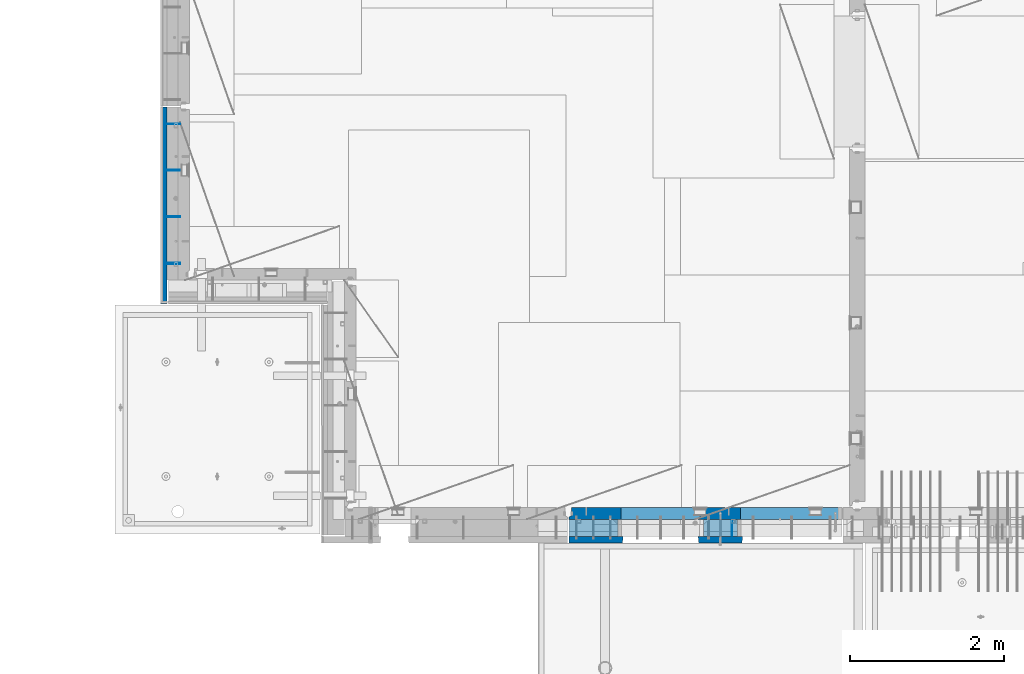
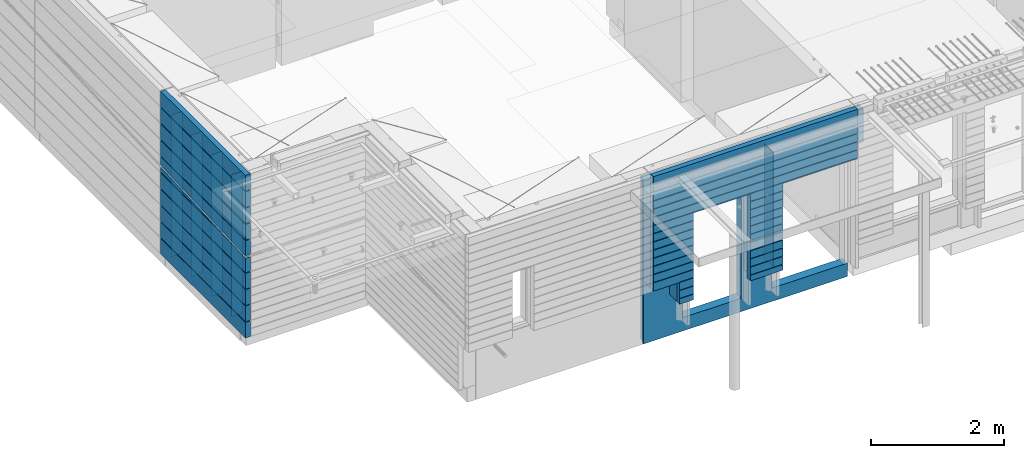
# One storey, part 207 of 325: 10 walls, 2 elements without a shape of their own.
"""IFC2X3 building model written with IfcOpenShell, lengths in millimetres."""

from ifc_helpers import new_model, si_unit, frame, origin_with_axes, place, context, subcontext, project, spatial, faceted_brep, material, type_object, element, aggregate, save


model = new_model("IFC2X3")

# Units and contexts
model_context = context("Model", 3, precision=1e-05, world=origin_with_axes())
body_context = subcontext(model_context, "Body", "Model", "MODEL_VIEW")
ifc_project = project(units=[si_unit("LENGTHUNIT", "METRE", prefix="MILLI"), si_unit("AREAUNIT", "SQUARE_METRE"), si_unit("VOLUMEUNIT", "CUBIC_METRE"), si_unit("MASSUNIT", "GRAM", prefix="KILO"), si_unit("TIMEUNIT", "SECOND"), si_unit("PLANEANGLEUNIT", "RADIAN"), si_unit("SOLIDANGLEUNIT", "STERADIAN"), si_unit("THERMODYNAMICTEMPERATUREUNIT", "DEGREE_CELSIUS"), si_unit("LUMINOUSINTENSITYUNIT", "LUMEN")], contexts=[model_context])

# Site, building, storey
site_placement = place(None, origin_with_axes())
site = spatial("IfcSite", under=ifc_project, at=site_placement, CompositionType="ELEMENT")
building_placement = place(site_placement, origin_with_axes())
building = spatial("IfcBuilding", under=site, at=building_placement, CompositionType="ELEMENT")
storey_placement = place(building_placement, origin_with_axes())
storey = spatial("IfcBuildingStorey", under=building, at=storey_placement, Name="1", CompositionType="ELEMENT", Elevation=0.0)

# Assembly, walls
assembly_1_placement = place(storey_placement, origin_with_axes())
assembly_1 = element("IfcElementAssembly", 1, at=assembly_1_placement, inside=storey, AssemblyPlace="NOTDEFINED", PredefinedType="REINFORCEMENT_UNIT")
ifc_material_1 = material(Name="Undefined")
wall_type_1 = type_object("IfcWallType", PredefinedType="NOTDEFINED")
wall_1_placement = place(assembly_1_placement, frame((7880.0, 11165.0, 83115.0), z_axis=(0.0, 0.0, 1.0), x_axis=(-1.0, 3.00000001838171e-08, 0.0)))
wall_1 = element("IfcWall", 2, at=wall_1_placement, type_object=wall_type_1, material=ifc_material_1, Name="(PD)", context=body_context, shape_type="Brep", body=[
    faceted_brep([(0.0, 5.0, -1300.0), (0.0, 5.0, 1300.0), (200.0, 5.0, 1300.0), (200.0, 5.0, -1300.0), (0.0, -5.0, 1300.0), (200.0, -5.0, 1300.0), (0.0, -5.0, -1300.0), (200.0, -5.0, -1300.0)], [[[0, 1, 2, 3]], [[1, 4, 5, 2]], [[4, 6, 7, 5]], [[6, 0, 3, 7]], [[5, 7, 3, 2]], [[6, 4, 1, 0]]]),
])
wall_2_placement = place(assembly_1_placement, frame((7880.0, 12975.0, 83115.0), z_axis=(0.0, 0.0, 1.0), x_axis=(-1.0, 3.00000001838171e-08, 0.0)))
wall_2 = element("IfcWall", 3, at=wall_2_placement, type_object=wall_type_1, material=ifc_material_1, Name="(PD)", context=body_context, shape_type="Brep", body=[
    faceted_brep([(0.0, 5.0, -1300.0), (0.0, 5.0, 1300.0), (200.0, 5.0, 1300.0), (200.0, 5.0, -1300.0), (0.0, -5.0, 1300.0), (200.0, -5.0, 1300.0), (0.0, -5.0, -1300.0), (200.0, -5.0, -1300.0)], [[[0, 1, 2, 3]], [[1, 4, 5, 2]], [[4, 6, 7, 5]], [[6, 0, 3, 7]], [[5, 7, 3, 2]], [[6, 4, 1, 0]]]),
])
wall_3_placement = place(assembly_1_placement, frame((7880.0, 12375.0, 83115.0), z_axis=(0.0, 0.0, 1.0), x_axis=(-1.0, 3.00000001838171e-08, 0.0)))
wall_3 = element("IfcWall", 4, at=wall_3_placement, type_object=wall_type_1, material=ifc_material_1, Name="(PD)", context=body_context, shape_type="Brep", body=[
    faceted_brep([(0.0, 5.0, -1300.0), (0.0, 5.0, 1300.0), (200.0, 5.0, 1300.0), (200.0, 5.0, -1300.0), (0.0, -5.0, 1300.0), (200.0, -5.0, 1300.0), (0.0, -5.0, -1300.0), (200.0, -5.0, -1300.0)], [[[0, 1, 2, 3]], [[1, 4, 5, 2]], [[4, 6, 7, 5]], [[6, 0, 3, 7]], [[5, 7, 3, 2]], [[6, 4, 1, 0]]]),
])
wall_4_placement = place(assembly_1_placement, frame((7880.0, 11775.0, 83115.0), z_axis=(0.0, 0.0, 1.0), x_axis=(-1.0, 3.00000001838171e-08, 0.0)))
wall_4 = element("IfcWall", 5, at=wall_4_placement, type_object=wall_type_1, material=ifc_material_1, Name="(PD)", context=body_context, shape_type="Brep", body=[
    faceted_brep([(0.0, 5.0, -1300.0), (0.0, 5.0, 1300.0), (200.0, 5.0, 1300.0), (200.0, 5.0, -1300.0), (0.0, -5.0, 1300.0), (200.0, -5.0, 1300.0), (0.0, -5.0, -1300.0), (200.0, -5.0, -1300.0)], [[[0, 1, 2, 3]], [[1, 4, 5, 2]], [[4, 6, 7, 5]], [[6, 0, 3, 7]], [[5, 7, 3, 2]], [[6, 4, 1, 0]]]),
])
wall_5_placement = place(assembly_1_placement, frame((7880.0, 11175.0, 83115.0), z_axis=(0.0, 0.0, 1.0), x_axis=(-1.0, 3.00000001838171e-08, 0.0)))
wall_5 = element("IfcWall", 6, at=wall_5_placement, type_object=wall_type_1, material=ifc_material_1, Name="(PD)", context=body_context, shape_type="Brep", body=[
    faceted_brep([(0.0, 5.0, -1300.0), (0.0, 5.0, 1300.0), (200.0, 5.0, 1300.0), (200.0, 5.0, -1300.0), (0.0, -5.0, 1300.0), (200.0, -5.0, 1300.0), (0.0, -5.0, -1300.0), (200.0, -5.0, -1300.0)], [[[0, 1, 2, 3]], [[1, 4, 5, 2]], [[4, 6, 7, 5]], [[6, 0, 3, 7]], [[5, 7, 3, 2]], [[6, 4, 1, 0]]]),
])
ifc_material_2 = material(Name="CONCRETE/C30/37")
wall_type_2 = type_object("IfcWallType", PredefinedType="NOTDEFINED")
wall_6_placement = place(assembly_1_placement, frame((7667.5, 10645.0, 83247.5), z_axis=(0.0, 0.0, 1.0), x_axis=(0.0, 1.0, 0.0)))
wall_6 = element("IfcWall", 7, at=wall_6_placement, type_object=wall_type_2, material=ifc_material_2, context=body_context, shape_type="Brep", body=[
    faceted_brep([(0.000115201512016938, 12.4999999999982, -32.6842012733541), (30.0001152015138, 12.4999999999964, -32.6842012732959), (30.0001152015138, 12.4999999999982, -31.2185204170964), (30.0001152015138, -42.4999999999991, -32.6842015973234), (0.0, -42.5, -32.6842015973234), (30.0001152015138, -42.4999999999991, 17.3157872826123), (30.0001152015138, 12.4999999999936, 17.3157872826123), (0.0, -42.5, 17.3157872826123), (4.43547978647985e-05, 12.4999999999982, 17.3157955949428), (0.0, 42.5, 1492.5), (2550.0, 42.5, 1492.5), (2550.0, 42.5, 1206.99999988925), (0.0, 42.5, 1206.99999988925), (2550.0, 32.4999991121613, 1205.00000040043), (10.0000008873085, 32.4999991121613, 1205.00000040043), (2550.0, 32.4999992501671, 1194.99999999921), (10.0000007493072, 32.4999992501671, 1194.99999999921), (2550.0, 42.5, 1192.99999994476), (0.0, 42.5, 1192.99999994476), (2550.0, 42.5, 906.999999889245), (0.0, 42.5, 906.999999889245), (2550.0, 32.4999991121613, 905.000000400425), (10.0000008873085, 32.4999991121613, 905.000000400425), (2550.0, 32.4999992501671, 894.999999999214), (10.0000007493072, 32.4999992501671, 894.999999999214), (2550.0, 42.5, 892.999999944761), (0.0, 42.5, 892.999999944761), (2550.0, 42.5, 606.999999889245), (0.0, 42.5, 606.999999889245), (2550.0, 32.4999991121613, 605.000000400425), (10.0000008873085, 32.4999991121613, 605.000000400425), (2550.0, 32.4999992501671, 594.999999999214), (10.0000007493072, 32.4999992501671, 594.999999999214), (2550.0, 42.5, 592.999999944761), (0.0, 42.5, 592.999999944761), (2550.0, 42.5, 306.999999889245), (0.0, 42.5, 306.999999889245), (2550.0, 32.4999991121613, 305.000000400425), (10.0000008873085, 32.4999991121613, 305.000000400425), (2550.0, 32.4999992501671, 294.999999999214), (10.0000007493072, 32.4999992501671, 294.999999999214), (2550.0, 42.5, 292.999999944761), (0.0, 42.5, 292.999999944761), (10.0000007493072, -42.5, 294.9999999992), (0.0, -42.5, 292.999999944761), (10.0000008873085, -42.5, 305.000000400425), (0.0, -42.5, 306.999999889245), (0.0, -42.5, 592.999999944761), (10.0000007493072, -42.5000000000009, 594.9999999992), (10.0000008873085, -42.5000000000009, 605.000000400425), (0.0, -42.5, 606.999999889245), (0.0, -42.5, 892.999999944761), (10.0000007493072, -42.5, 894.9999999992), (10.0000008873085, -42.5, 905.000000400425), (0.0, -42.5, 906.999999889245), (0.0, -42.5, 1192.99999994476), (10.0000007493072, -42.5, 1194.9999999992), (10.0000008873085, -42.5, 1205.00000040043), (0.0, -42.5, 1206.99999988925), (0.0, -42.5, 1492.5), (2550.0, -42.5, 1492.5), (2550.0, 42.5, 6.99999988924537), (812.268372506769, 42.5, 6.99999988924537), (2550.0, 42.5, 91.8986658797949), (2550.0, 32.4999991121613, 5.00000040042505), (771.331776788546, 32.4999991121613, 5.00000040042505), (2550.0, 32.4999992501671, -5.0000000007858), (566.648737670199, 32.4999992501671, -5.0000000007858), (2550.0, 42.5, -7.00000005523907), (525.712130374386, 42.5, -7.00000005523907), (2550.0, 42.5, -293.000000110755), (0.0, 42.5, -293.000000110755), (0.0, 42.5, -32.6842012733541), (2550.0, 32.4999991121613, -294.999999599575), (10.0000008873085, 32.4999991121613, -294.999999599575), (2550.0, 32.4999992501671, -305.000000000786), (10.0000007493072, 32.4999992501671, -305.000000000786), (2550.0, 42.5, -307.000000055239), (0.0, 42.5, -307.000000055239), (2550.0, 42.5, -593.000000110755), (0.0, 42.5, -593.000000110755), (2550.0, 32.4999991121613, -594.999999599575), (10.0000008873085, 32.4999991121613, -594.999999599575), (2550.0, 32.4999992501671, -605.000000000786), (10.0000007493072, 32.4999992501671, -605.000000000786), (2550.0, 42.5, -607.000000055239), (0.0, 42.5, -607.000000055239), (2550.0, 42.5, -893.000000110755), (0.0, 42.5, -893.000000110755), (2550.0, 32.4999991121613, -894.999999599575), (10.0000008873085, 32.4999991121613, -894.999999599575), (2550.0, 32.4999992501671, -905.000000000786), (10.0000007493072, 32.4999992501671, -905.000000000786), (2550.0, 42.5, -907.000000055239), (0.0, 42.5, -907.000000055239), (2550.0, 42.5, -1193.00000011075), (0.0, 42.5, -1193.00000011075), (2550.0, 32.4999991121613, -1194.99999959957), (10.0000008873085, 32.4999991121613, -1194.99999959957), (2550.0, 32.4999992501671, -1205.00000000079), (10.0000007493072, 32.4999992501671, -1205.00000000079), (2550.0, 42.5, -1207.00000005524), (0.0, 42.5, -1207.00000005524), (2550.0, 42.5, -1492.5), (0.0, 42.5, -1492.5), (0.0, -42.5, -1492.5), (2550.0, -42.5, -1492.5), (0.0, -42.5, -1207.00000005524), (10.0000007493072, -42.5, -1205.0000000008), (10.0000008873085, -42.5, -1194.99999959957), (0.0, -42.5, -1193.00000011075), (0.0, -42.5, -907.000000055239), (10.0000007493072, -42.5, -905.0000000008), (10.0000008873085, -42.5, -894.999999599575), (0.0, -42.5, -893.000000110755), (0.0, -42.5, -607.000000055239), (10.0000007493072, -42.5, -605.0000000008), (10.0000008873085, -42.5, -594.999999599575), (0.0, -42.5, -593.000000110755), (0.0, -42.5, -307.000000055239), (10.0000007493072, -42.5, -305.0000000008), (10.0000008873085, -42.5, -294.999999599575), (0.0, -42.5, -293.000000110755), (2549.99999999073, 12.4999999999982, 91.8986658797949), (2550.0, 12.4999999999982, 141.86737513663), (2550.0, 42.5, 141.898665707573), (0.0, 42.5, 17.3157955949428)], [[[0, 1, 2]], [[3, 1, 0, 4]], [[5, 6, 2, 1, 3]], [[7, 8, 6, 5]], [[9, 10, 11, 12]], [[11, 13, 14, 12]], [[13, 15, 16, 14]], [[15, 17, 18, 16]], [[19, 20, 18, 17]], [[19, 21, 22, 20]], [[21, 23, 24, 22]], [[23, 25, 26, 24]], [[27, 28, 26, 25]], [[27, 29, 30, 28]], [[29, 31, 32, 30]], [[31, 33, 34, 32]], [[35, 36, 34, 33]], [[35, 37, 38, 36]], [[37, 39, 40, 38]], [[39, 41, 42, 40]], [[43, 40, 42, 44]], [[45, 38, 40, 43]], [[46, 36, 38, 45]], [[36, 46, 47, 34]], [[48, 32, 34, 47]], [[49, 30, 32, 48]], [[50, 28, 30, 49]], [[28, 50, 51, 26]], [[52, 24, 26, 51]], [[53, 22, 24, 52]], [[54, 20, 22, 53]], [[20, 54, 55, 18]], [[56, 16, 18, 55]], [[57, 14, 16, 56]], [[58, 12, 14, 57]], [[59, 9, 12, 58]], [[9, 59, 60, 10]], [[61, 62, 63]], [[61, 64, 65, 62]], [[64, 66, 67, 65]], [[66, 68, 69, 67]], [[68, 70, 71, 72, 69]], [[70, 73, 74, 71]], [[73, 75, 76, 74]], [[75, 77, 78, 76]], [[79, 80, 78, 77]], [[79, 81, 82, 80]], [[81, 83, 84, 82]], [[83, 85, 86, 84]], [[87, 88, 86, 85]], [[87, 89, 90, 88]], [[89, 91, 92, 90]], [[91, 93, 94, 92]], [[95, 96, 94, 93]], [[95, 97, 98, 96]], [[97, 99, 100, 98]], [[99, 101, 102, 100]], [[103, 104, 102, 101]], [[105, 104, 103, 106]], [[104, 105, 107, 102]], [[108, 100, 102, 107]], [[109, 98, 100, 108]], [[110, 96, 98, 109]], [[96, 110, 111, 94]], [[112, 92, 94, 111]], [[113, 90, 92, 112]], [[114, 88, 90, 113]], [[88, 114, 115, 86]], [[116, 84, 86, 115]], [[117, 82, 84, 116]], [[118, 80, 82, 117]], [[80, 118, 119, 78]], [[120, 76, 78, 119]], [[121, 74, 76, 120]], [[122, 71, 74, 121]], [[72, 71, 122, 4, 0]], [[123, 63, 62, 65, 67, 69, 72, 0, 2]], [[124, 123, 2, 6, 8]], [[41, 39, 37, 35, 33, 31, 29, 27, 25, 23, 21, 19, 17, 15, 13, 11, 10, 60, 106, 103, 101, 99, 97, 95, 93, 91, 89, 87, 85, 83, 81, 79, 77, 75, 73, 70, 68, 66, 64, 61, 63, 123, 124, 125]], [[42, 41, 125, 126]], [[124, 8, 126, 125]], [[44, 42, 126, 8, 7]], [[4, 122, 121, 120, 119, 118, 117, 116, 115, 114, 113, 112, 111, 110, 109, 108, 107, 105, 106, 60, 59, 58, 57, 56, 55, 54, 53, 52, 51, 50, 49, 48, 47, 46, 45, 43, 44, 7, 5, 3]]]),
])
aggregate(assembly_1, [wall_1, wall_2, wall_3, wall_4, wall_5, wall_6])

assembly_2_placement = place(storey_placement, origin_with_axes())
assembly_2 = element("IfcElementAssembly", 8, at=assembly_2_placement, inside=storey, AssemblyPlace="NOTDEFINED", PredefinedType="REINFORCEMENT_UNIT")
wall_7_placement = place(assembly_2_placement, frame((16460.0, 7587.5, 83247.5), z_axis=(0.0, 0.0, 1.0), x_axis=(-1.0, 3.00000001838171e-08, 0.0)))
wall_7 = element("IfcWall", 9, at=wall_7_placement, type_object=wall_type_2, material=ifc_material_2, context=body_context, shape_type="Brep", body=[
    faceted_brep([(3085.00061035156, -42.5, -607.5), (3085.00061035156, 42.4999995453572, -607.5), (3540.00000000003, 42.5, -607.5), (3540.00000000003, -42.5, -607.5), (3085.00061035156, -42.5, -1007.5), (3085.00061035156, 42.4999996457309, -1007.5), (3085.00061035156, 42.4999992916191, -907.000000055239), (3085.00061035156, 32.4999992501716, -905.000000000757), (3085.00061035156, 32.4999991121731, -894.99999959956), (3085.00061035156, 42.4999992675721, -893.000000110755), (3085.00061035156, 42.4999992916191, -757.000000055239), (3085.00061035156, 32.4999992501716, -755.000000000757), (3085.00061035156, 32.4999991121731, -744.99999959956), (3085.00061035156, 42.4999992675721, -743.000000110755), (0.0, 42.5, 1492.5), (3540.00000000003, 42.5, 1492.5), (3540.00000000003, 42.5, 1356.99999988925), (0.0, 42.5, 1356.99999988925), (3540.0, 32.4999991121686, 1355.00000040043), (-3.63797880709171e-12, 32.4999991127006, 1355.00000040044), (3540.0, 32.4999992501707, 1344.99999999924), (-3.63797880709171e-12, 32.4999992507037, 1344.99999999926), (3540.00000000003, 42.5, 1342.99999994476), (0.0, 42.5, 1342.99999994476), (3540.00000000003, 42.5, 1206.99999988925), (0.0, 42.5, 1206.99999988925), (3540.0, 32.4999991121686, 1205.00000040043), (0.0, 32.4999991127006, 1205.00000040044), (3540.0, 32.4999992501707, 1194.99999999924), (0.0, 32.4999992507037, 1194.99999999926), (3540.00000000003, 42.5, 1192.99999994476), (0.0, 42.5, 1192.99999994476), (3540.00000000003, 42.5, 1056.99999988925), (0.0, 42.5, 1056.99999988925), (3540.0, 32.4999991121686, 1055.00000040043), (0.0, 32.4999991127006, 1055.00000040044), (3540.0, 32.4999992501707, 1044.99999999924), (0.0, 32.4999992507037, 1044.99999999926), (3540.00000000003, 42.5, 1042.99999994476), (0.0, 42.5, 1042.99999994476), (3540.00000000003, 42.5, 906.999999889245), (0.0, 42.5, 906.999999889245), (3540.0, 32.4999991121686, 905.000000400425), (0.0, 32.4999991127006, 905.00000040044), (3540.0, 32.4999992501707, 894.999999999243), (0.0, 32.4999992507037, 894.999999999258), (3540.00000000003, 42.5, 892.999999944761), (0.0, 42.5, 892.999999944761), (3540.00000000003, 42.5, 756.999999889245), (0.0, 42.5, 756.999999889245), (3540.0, 32.4999991121686, 755.000000400425), (0.0, 32.4999991127006, 755.00000040044), (3540.0, 32.4999992501707, 744.999999999243), (0.0, 32.4999992507037, 744.999999999258), (3540.00000000003, 42.5, 742.999999944761), (0.0, 42.5, 742.999999944761), (3540.00000000003, 42.5, 606.999999889245), (0.0, 42.5, 606.999999889245), (3540.0, 32.4999991121686, 605.000000400425), (3.63797880709171e-12, 32.4999991127006, 605.00000040044), (3540.0, 32.4999992501707, 594.999999999243), (3.63797880709171e-12, 32.4999992507037, 594.999999999258), (3540.00000000003, 42.5, 592.999999944761), (0.0, 42.5, 592.999999944761), (1294.99798990771, 42.4999997026416, -907.000000055239), (1854.9985621123, 42.4999995740536, -907.000000055239), (1854.9985621123, 42.4999996471661, -1007.5), (1294.99798990771, 42.4999997536825, -1007.5), (1856.1752288672, 32.4999992501716, -905.000000000757), (1293.82132315282, 32.4999992501716, -905.000000000757), (1856.17522888344, 32.4999991121731, -894.99999959956), (1293.82132313658, 32.4999991121731, -894.99999959956), (1854.9985621123, 42.4999995595945, -893.000000110755), (1294.99798990771, 42.4999996925471, -893.000000110755), (1854.9985621123, 42.4999995740536, -757.000000055239), (1294.99798990771, 42.4999997026416, -757.000000055239), (1856.1752288672, 32.4999992501716, -755.000000000757), (1293.82132315282, 32.4999992501716, -755.000000000757), (1856.17522888344, 32.4999991121731, -744.99999959956), (1293.82132313658, 32.4999991121731, -744.99999959956), (1854.9985621123, 42.4999995595945, -743.000000110755), (1294.99798990771, 42.4999996925471, -743.000000110755), (1854.9985621123, 42.4999995595563, -607.000000055239), (1294.99798990771, 42.4999996925208, -607.000000055239), (1856.1752288672, 32.4999992501716, -605.000000000757), (1293.82132315282, 32.4999992501716, -605.000000000757), (1856.17522888344, 32.4999991121695, -594.999999599575), (1293.82132313658, 32.4999991121695, -594.999999599575), (1854.9985621123, 42.4999995446015, -593.000000110755), (1294.99798990771, 42.4999996820807, -593.000000110755), (1854.9985621123, 42.5, -457.000000055239), (1294.99798990771, 42.5, -457.000000055239), (1856.1752288672, 32.4999992501707, -455.000000000757), (1293.82132315282, 32.4999992501707, -455.000000000757), (1856.17522888344, 32.4999991121686, -444.999999599575), (1293.82132313658, 32.4999991121686, -444.999999599575), (1854.9985621123, 42.5, -443.000000110755), (1294.99798990771, 42.5, -443.000000110755), (1854.9985621123, 42.5, -307.000000055239), (1294.99798990771, 42.5, -307.000000055239), (1856.1752288672, 32.4999992501707, -305.000000000757), (1293.82132315282, 32.4999992501707, -305.000000000757), (1856.17522888344, 32.4999991121686, -294.999999599575), (1293.82132313658, 32.4999991121686, -294.999999599575), (1854.9985621123, 42.5, -293.000000110755), (1294.99798990771, 42.5, -293.000000110755), (1854.9985621123, 42.5, -157.000000055239), (1294.99798990771, 42.5, -157.000000055239), (1856.1752288672, 32.4999992501707, -155.000000000757), (1293.82132315282, 32.4999992501707, -155.000000000757), (1856.17522888344, 32.4999991121686, -144.999999599575), (1293.82132313658, 32.4999991121686, -144.999999599575), (1854.9985621123, 42.5, -143.000000110755), (1294.99798990771, 42.5, -143.000000110755), (1854.9985621123, 42.5, -7.00000005523907), (1294.99798990771, 42.5, -7.00000005523907), (1856.1752288672, 32.4999992501707, -5.0000000007567), (1293.82132315282, 32.4999992501707, -5.0000000007567), (1856.17522888344, 32.4999991121686, 5.00000040042505), (1293.82132313658, 32.4999991121686, 5.00000040042505), (1854.9985621123, 42.5, 6.99999988924537), (1294.99798990771, 42.5, 6.99999988924537), (1854.9985621123, 42.5, 142.999999944761), (1294.99798990771, 42.5, 142.999999944761), (1856.1752288672, 32.4999992501707, 144.999999999243), (1293.82132315282, 32.4999992501707, 144.999999999243), (1856.17522888344, 32.4999991121686, 155.000000400425), (1293.82132313658, 32.4999991121686, 155.000000400425), (1854.9985621123, 42.5, 156.999999889245), (1294.99798990771, 42.5, 156.999999889245), (1854.9985621123, 42.5, 292.999999944761), (1294.99798990771, 42.5, 292.999999944761), (1856.1752288672, 32.4999992501707, 294.999999999243), (1293.82132315282, 32.4999992501707, 294.999999999243), (1856.17522888344, 32.4999991121686, 305.000000400425), (1293.82132313658, 32.4999991121686, 305.000000400425), (1854.9985621123, 42.5, 306.999999889245), (1294.99798990771, 42.5, 306.999999889245), (1854.9985621123, 42.5, 442.999999944761), (1294.99798990771, 42.5, 442.999999944761), (1856.1752288672, 32.4999992501707, 444.999999999243), (1293.82132315282, 32.4999992501707, 444.999999999243), (1856.17522888344, 32.4999991121686, 455.000000400425), (1293.82132313658, 32.4999991121686, 455.000000400425), (1854.9985621123, 42.5, 456.999999889245), (1294.99798990771, 42.5, 456.999999889245), (3540.00000000003, 42.5, 456.999999889245), (2844.9985621123, 42.5, 456.999999889245), (2844.9985621123, 42.5, 582.5), (2835.00062093583, 42.5, 582.5), (1865.00062093583, 42.5, 582.5), (1854.9985621123, 42.5, 582.5), (1294.99798990771, 42.5, 582.5), (1285.00004873124, 42.5, 582.5), (17.352990005882, 42.5, 582.5), (15.0000487312391, 42.5, 582.5), (4.9979899077116, 42.5, 582.5), (0.0, 42.5, 582.5), (3540.0, 32.4999991121686, 455.000000400425), (2843.82189534117, 32.4999991121686, 455.000000400425), (3540.0, 32.4999992501707, 444.999999999243), (2843.82189535741, 32.4999992501707, 444.999999999243), (3540.00000000003, 42.5, 442.999999944761), (2844.9985621123, 42.5, 442.999999944761), (3540.00000000003, 42.5, 306.999999889245), (2844.9985621123, 42.5, 306.999999889245), (3540.0, 32.4999991121686, 305.000000400425), (2843.82189534117, 32.4999991121686, 305.000000400425), (3540.0, 32.4999992501707, 294.999999999243), (2843.82189535741, 32.4999992501707, 294.999999999243), (3540.00000000003, 42.5, 292.999999944761), (2844.9985621123, 42.5, 292.999999944761), (3540.00000000003, 42.5, 156.999999889245), (2844.9985621123, 42.5, 156.999999889245), (3540.0, 32.4999991121686, 155.000000400425), (2843.82189534117, 32.4999991121686, 155.000000400425), (3540.0, 32.4999992501707, 144.999999999243), (2843.82189535741, 32.4999992501707, 144.999999999243), (3540.00000000003, 42.5, 142.999999944761), (2844.9985621123, 42.5, 142.999999944761), (3540.00000000003, 42.5, 6.99999988924537), (2844.9985621123, 42.5, 6.99999988924537), (3540.0, 32.4999991121686, 5.00000040042505), (2843.82189534117, 32.4999991121686, 5.00000040042505), (3540.0, 32.4999992501707, -5.0000000007567), (2843.82189535741, 32.4999992501707, -5.0000000007567), (3540.00000000003, 42.5, -7.00000005523907), (2844.9985621123, 42.5, -7.00000005523907), (3540.00000000003, 42.5, -143.000000110755), (2844.9985621123, 42.5, -143.000000110755), (3540.0, 32.4999991121686, -144.999999599575), (2843.82189534117, 32.4999991121686, -144.999999599575), (3540.0, 32.4999992501707, -155.000000000757), (2843.82189535741, 32.4999992501707, -155.000000000757), (3540.00000000003, 42.5, -157.000000055239), (2844.9985621123, 42.5, -157.000000055239), (3540.00000000003, 42.5, -293.000000110755), (2844.9985621123, 42.5, -293.000000110755), (3540.0, 32.4999991121686, -294.999999599575), (2843.82189534117, 32.4999991121686, -294.999999599575), (3540.0, 32.4999992501707, -305.000000000757), (2843.82189535741, 32.4999992501707, -305.000000000757), (3540.00000000003, 42.5, -307.000000055239), (2844.9985621123, 42.5, -307.000000055239), (3540.00000000003, 42.5, -443.000000110755), (2844.9985621123, 42.5, -443.000000110755), (3540.0, 32.4999991121686, -444.999999599575), (2843.82189534117, 32.4999991121686, -444.999999599575), (3540.0, 32.4999992501707, -455.000000000757), (2843.82189535741, 32.4999992501707, -455.000000000757), (3540.00000000003, 42.5, -457.000000055239), (2844.9985621123, 42.5, -457.000000055239), (3085.0, 32.4999991121695, -594.999999599575), (3085.0, 32.4999992501716, -605.000000000757), (2843.82189535741, 32.4999992501716, -605.000000000757), (2843.82189534117, 32.4999991121695, -594.999999599575), (3085.0, 42.4999992426392, -593.000000110755), (2844.9985621123, 42.499999301559, -593.000000110755), (3085.0, 42.4999992675093, -607.000000055239), (2844.9985621123, 42.4999993244946, -607.000000055239), (2834.99689544563, -42.5, 582.5), (2834.99689544563, -42.5, 587.502857142856), (2844.9985621123, 42.4999993245528, -743.000000110755), (2843.82189534117, 32.4999991121731, -744.99999959956), (2843.82189535741, 32.4999992501716, -755.000000000757), (2844.9985621123, 42.4999993467291, -757.000000055239), (2844.9985621123, 42.4999993245528, -893.000000110755), (2843.82189534117, 32.4999991121731, -894.99999959956), (2843.82189535741, 32.4999992501716, -905.000000000757), (2844.9985621123, 42.4999993467291, -907.000000055239), (2844.9985621123, 42.4999994588616, -1007.5), (2834.99689544563, -42.5, -1007.5), (1865.00022877897, -42.5, 587.502857142856), (1865.00022877897, -42.5, 582.5), (1865.00022877897, -42.5, -1007.5), (1284.99918004842, -42.5, -1007.5), (1284.99632324104, -42.5, 587.502857142856), (14.9996565743786, -42.5, 587.502857142856), (14.999657517601, -42.5, 582.499999999927), (9.38489392865449e-08, -42.5, 582.5), (0.0, -42.5, 1492.5), (3540.00000000003, -42.5, 1492.5)], [[[0, 1, 2, 3]], [[4, 5, 6, 7, 8, 9, 10, 11, 12, 13, 1, 0]], [[14, 15, 16, 17]], [[17, 16, 18, 19]], [[19, 18, 20, 21]], [[21, 20, 22, 23]], [[24, 25, 23, 22]], [[25, 24, 26, 27]], [[27, 26, 28, 29]], [[29, 28, 30, 31]], [[32, 33, 31, 30]], [[33, 32, 34, 35]], [[35, 34, 36, 37]], [[37, 36, 38, 39]], [[40, 41, 39, 38]], [[41, 40, 42, 43]], [[43, 42, 44, 45]], [[45, 44, 46, 47]], [[47, 46, 48, 49]], [[49, 48, 50, 51]], [[51, 50, 52, 53]], [[53, 52, 54, 55]], [[56, 57, 55, 54]], [[57, 56, 58, 59]], [[59, 58, 60, 61]], [[61, 60, 62, 63]], [[64, 65, 66, 67]], [[68, 65, 64, 69]], [[70, 68, 69, 71]], [[72, 70, 71, 73]], [[74, 72, 73, 75]], [[76, 74, 75, 77]], [[78, 76, 77, 79]], [[80, 78, 79, 81]], [[82, 80, 81, 83]], [[84, 82, 83, 85]], [[86, 84, 85, 87]], [[88, 86, 87, 89]], [[90, 88, 89, 91]], [[92, 90, 91, 93]], [[94, 92, 93, 95]], [[96, 94, 95, 97]], [[98, 96, 97, 99]], [[100, 98, 99, 101]], [[102, 100, 101, 103]], [[104, 102, 103, 105]], [[106, 104, 105, 107]], [[108, 106, 107, 109]], [[110, 108, 109, 111]], [[112, 110, 111, 113]], [[114, 112, 113, 115]], [[116, 114, 115, 117]], [[118, 116, 117, 119]], [[120, 118, 119, 121]], [[122, 120, 121, 123]], [[124, 122, 123, 125]], [[126, 124, 125, 127]], [[128, 126, 127, 129]], [[130, 128, 129, 131]], [[132, 130, 131, 133]], [[134, 132, 133, 135]], [[136, 134, 135, 137]], [[138, 136, 137, 139]], [[140, 138, 139, 141]], [[142, 140, 141, 143]], [[144, 142, 143, 145]], [[63, 62, 146, 147, 148, 149, 150, 151, 144, 145, 152, 153, 154, 155, 156, 157]], [[146, 158, 159, 147]], [[158, 160, 161, 159]], [[160, 162, 163, 161]], [[162, 164, 165, 163]], [[164, 166, 167, 165]], [[166, 168, 169, 167]], [[168, 170, 171, 169]], [[170, 172, 173, 171]], [[172, 174, 175, 173]], [[174, 176, 177, 175]], [[176, 178, 179, 177]], [[178, 180, 181, 179]], [[180, 182, 183, 181]], [[182, 184, 185, 183]], [[184, 186, 187, 185]], [[186, 188, 189, 187]], [[188, 190, 191, 189]], [[190, 192, 193, 191]], [[192, 194, 195, 193]], [[194, 196, 197, 195]], [[196, 198, 199, 197]], [[198, 200, 201, 199]], [[200, 202, 203, 201]], [[202, 204, 205, 203]], [[204, 206, 207, 205]], [[206, 208, 209, 207]], [[208, 210, 211, 209]], [[212, 213, 214, 215]], [[216, 212, 215, 217]], [[218, 213, 212, 216]], [[213, 218, 219, 214]], [[220, 221, 148, 147, 159, 161, 163, 165, 167, 169, 171, 173, 175, 177, 179, 181, 183, 185, 187, 189, 191, 193, 195, 197, 199, 201, 203, 205, 207, 209, 211, 217, 215, 214, 219, 222, 223, 224, 225, 226, 227, 228, 229, 230, 231]], [[150, 149, 148, 221, 232, 151]], [[65, 68, 70, 72, 74, 76, 78, 80, 82, 84, 86, 88, 90, 92, 94, 96, 98, 100, 102, 104, 106, 108, 110, 112, 114, 116, 118, 120, 122, 124, 126, 128, 130, 132, 134, 136, 138, 140, 142, 144, 151, 232, 233, 234, 66]], [[66, 234, 235, 67]], [[236, 152, 145, 143, 141, 139, 137, 135, 133, 131, 129, 127, 125, 123, 121, 119, 117, 115, 113, 111, 109, 107, 105, 103, 101, 99, 97, 95, 93, 91, 89, 87, 85, 83, 81, 79, 77, 75, 73, 71, 69, 64, 67, 235]], [[155, 154, 153, 152, 236, 237, 156]], [[237, 238, 156]], [[239, 157, 156, 238]], [[240, 14, 17, 19, 21, 23, 25, 27, 29, 31, 33, 35, 37, 39, 41, 43, 45, 47, 49, 51, 53, 55, 57, 59, 61, 63, 157, 239]], [[14, 240, 241, 15]], [[210, 208, 206, 204, 202, 200, 198, 196, 194, 192, 190, 188, 186, 184, 182, 180, 178, 176, 174, 172, 170, 168, 166, 164, 162, 160, 158, 146, 62, 60, 58, 56, 54, 52, 50, 48, 46, 44, 42, 40, 38, 36, 34, 32, 30, 28, 26, 24, 22, 20, 18, 16, 15, 241, 3, 2]], [[222, 219, 218, 216, 217, 211, 210, 2, 1, 13]], [[223, 222, 13, 12]], [[224, 223, 12, 11]], [[225, 224, 11, 10]], [[226, 225, 10, 9]], [[227, 226, 9, 8]], [[228, 227, 8, 7]], [[229, 228, 7, 6]], [[230, 229, 6, 5]], [[231, 230, 5, 4]], [[241, 240, 239, 238, 237, 236, 235, 234, 233, 232, 221, 220, 231, 4, 0, 3]]]),
])
ifc_material_3 = material(Name="CONCRETE/C25/30")
wall_type_3 = type_object("IfcWallType", PredefinedType="NOTDEFINED")
wall_8_placement = place(assembly_2_placement, frame((16740.0, 7925.0, 82977.5), z_axis=(0.0, 0.0, 1.0), x_axis=(-1.0, 3.00000001838171e-08, 0.0)))
wall_8 = element("IfcWall", 10, at=wall_8_placement, type_object=wall_type_3, material=ifc_material_3, context=body_context, shape_type="Brep", body=[
    faceted_brep([(3141.15446708968, 75.0, -1227.5), (3141.15446708968, 75.0000000000009, -1247.5), (3145.00062093583, -75.0, -1247.5), (3145.00062093583, -75.0, -1227.5), (2118.84677478199, 75.0000000000009, -1247.5), (2115.00062093583, -75.0, -1247.5), (2115.00062093583, -75.0, -1227.5), (2118.84677478199, 75.0, -1227.5), (280.0, 75.0, -1492.5), (280.0, -75.0, -1492.5), (280.0, -75.0, -1247.5), (280.0, 75.0, -1247.5), (3787.50000342932, -75.0000005658367, 1492.5), (3787.50000342932, -75.0, -1492.5), (3787.50000063558, 32.0000002682145, -1492.5), (3787.50000063558, 32.0000002682145, 1492.5), (3820.00000000003, 75.0, -1492.5), (3820.00000000003, 45.0, -1492.5), (3820.00000000003, 45.0, 1492.5), (3820.00000000003, 75.0, 1492.5), (0.0, -75.0, 1492.5), (0.0, 75.0, 1492.5), (0.0, 75.0, 882.503662109375), (0.0, -75.0, 882.503662109375), (26.999999589385, -75.0, 882.503662109375), (26.999999589385, -75.0000006096761, 1492.5), (119.999998466614, -54.9999949228195, 1492.5), (133.00000093603, -75.0000000198697, 1492.5), (39.9999999999382, -55.0000000000309, 1492.5), (119.999998466614, -54.9999949228195, 882.503662109375), (133.00000093603, -75.0, 882.503662109375), (39.9999999999382, -55.0000000000309, 882.503662109375), (268.846202577392, 75.0, 882.503662109375), (265.000048731239, -75.0, 882.503662109375), (268.846202577392, 75.0, 883.653846153844), (265.000048731239, -75.0, 887.5), (1591.15389488508, 75.0, 883.653846153844), (1595.00004873124, -75.0, 887.5), (1591.15389488508, 75.0, 863.653846153844), (1591.15389488508, 75.0, -1227.5), (1595.00004873124, -75.0, -1227.5), (1595.00004873124, -75.0, 867.5), (1591.15389488508, 75.0, -1247.5), (1595.00004873124, -75.0, -1247.5), (1585.00004873124, -75.0, -1247.5), (1585.00004873124, 75.0, -1247.5), (2115.00062093583, -75.0, 867.5), (2118.84677478199, 75.0, 863.653846153844), (2118.84677478199, 75.0, 883.653846153844), (2115.00062093583, -75.0, 887.5), (3141.15446708968, 75.0, 863.653846153844), (3141.15446708968, 75.0, 883.653846153844), (3145.00062093583, -75.0, 887.5), (3145.00062093583, -75.0, 867.5)], [[[0, 1, 2, 3]], [[2, 1, 4, 5]], [[6, 5, 4, 7]], [[8, 9, 10, 11]], [[12, 13, 14, 15]], [[9, 8, 16, 17, 14, 13]], [[15, 14, 17, 18]], [[16, 19, 18, 17]], [[20, 21, 22, 23]], [[20, 23, 24, 25]], [[26, 27, 12, 15, 18, 19, 21, 20, 25, 28]], [[26, 29, 30, 27]], [[28, 31, 29, 26]], [[25, 24, 31, 28]], [[23, 22, 32, 33, 30, 29, 31, 24]], [[34, 35, 33, 32]], [[35, 34, 36, 37]], [[38, 39, 40, 41, 37, 36]], [[39, 42, 43, 40]], [[10, 44, 43, 42, 45, 11]], [[46, 6, 7, 47, 48, 49]], [[42, 39, 38, 36, 34, 32, 22, 21, 19, 16, 8, 11, 45], [1, 0, 50, 51, 48, 47, 7, 4]], [[49, 48, 51, 52]], [[50, 0, 3, 53, 52, 51]], [[10, 9, 13, 12, 27, 30, 33, 35, 37, 41, 40, 43, 44], [46, 49, 52, 53, 3, 2, 5, 6]]]),
])
wall_type_4 = type_object("IfcWallType", PredefinedType="NOTDEFINED")
wall_9_placement = place(assembly_2_placement, frame((15035.0, 7880.0, 83365.0), z_axis=(0.0, 0.0, 1.0), x_axis=(0.0, -1.0, 0.0)))
wall_9 = element("IfcWall", 11, at=wall_9_placement, type_object=wall_type_4, material=ifc_material_1, Name="(PD)", context=body_context, shape_type="Brep", body=[
    faceted_brep([(0.0, 5.0, -1050.0), (0.0, 5.0, 1050.0), (280.0, 5.0, 1050.0), (280.0, 5.0, -1050.0), (0.0, -5.0, 1050.0), (280.0, -5.0, 1050.0), (0.0, -5.0, -1050.0), (280.0, -5.0, -1050.0)], [[[0, 1, 2, 3]], [[1, 4, 5, 2]], [[4, 6, 7, 5]], [[6, 0, 3, 7]], [[5, 7, 3, 2]], [[6, 4, 1, 0]]]),
])
ifc_material_4 = material(Name="COS5gt")
wall_type_5 = type_object("IfcWallType", PredefinedType="NOTDEFINED")
wall_10_placement = place(assembly_2_placement, frame((16460.0, 7740.0, 83047.5), z_axis=(0.0, 0.0, 1.0), x_axis=(-1.0, 3.00000001838171e-08, 0.0)))
wall_10 = element("IfcWall", 12, at=wall_10_placement, type_object=wall_type_5, material=ifc_material_4, context=body_context, shape_type="Brep", body=[
    faceted_brep([(1355.0002394661, -110.0, -807.5), (1355.00004873124, 90.0, -807.5), (1795.00062093583, 90.0, -807.5), (1795.00062093583, -110.0, -807.5), (2905.00062093583, -110.0, -807.5), (2905.00062093583, 110.0, -807.5), (3084.99966726151, 110.0, -807.5), (3084.99966726151, -110.0, -807.5), (3145.0, 110.0, -357.5), (3145.0, 90.0, -357.5), (3145.0, 90.0, -407.5), (3145.0, 110.0, -407.5), (3540.0, 110.0, -357.5), (3540.0, 90.0, -357.5), (3540.0, 90.0, -407.5), (3084.99966726151, -110.0, -407.5), (3084.99966726151, 110.0, -407.5), (3540.0, -110.0, -407.5), (3540.0, 110.0, 1292.5), (3540.0, -110.0, 1292.5), (0.0, 110.0, 1292.5), (0.0, -110.0, 1292.5), (0.0, 110.0, 857.5), (0.0, -110.0, 857.5), (1355.00004873124, 110.0, 857.5), (1355.00004873124, -110.0, 857.5), (1795.00062093583, 110.0, -757.5), (1795.00062093583, 90.0, -757.5), (1355.00004873124, 90.0, -757.5), (1355.00004873124, 110.0, -757.5), (1795.00062093583, -110.0, 857.5), (1795.00062093583, 110.0, 857.5), (2905.00062093583, 110.0, 857.5), (2905.00062093583, -110.0, 857.5), (1795.00062093583, 110.0, 837.5), (1795.00062093583, -110.0, 837.5), (2905.00062093583, -110.0, 837.5), (2905.00062093583, 110.0, 837.5)], [[[0, 1, 2, 3]], [[4, 5, 6, 7]], [[8, 9, 10, 11]], [[12, 13, 9, 8]], [[9, 13, 14, 10]], [[15, 16, 11, 10, 14, 17]], [[13, 12, 18, 19, 17, 14]], [[20, 21, 19, 18]], [[21, 20, 22, 23]], [[23, 22, 24, 25]], [[26, 27, 28, 29]], [[30, 31, 32, 33]], [[27, 26, 34, 31, 30, 35, 3, 2]], [[28, 27, 2, 1]], [[25, 24, 29, 28, 1, 0]], [[35, 30, 33, 36, 4, 7, 15, 17, 19, 21, 23, 25, 0, 3]], [[16, 15, 7, 6]], [[37, 32, 31, 34, 26, 29, 24, 22, 20, 18, 12, 8, 11, 16, 6, 5]], [[36, 33, 32, 37, 5, 4]]]),
])
aggregate(assembly_2, [wall_9, wall_7, wall_10, wall_8])

save(model, "model.ifc")
